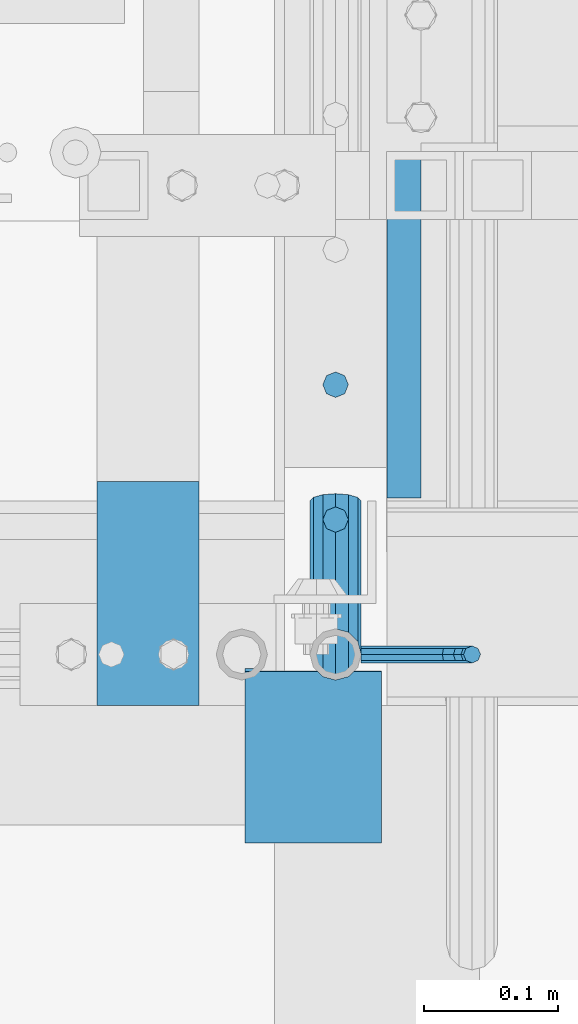
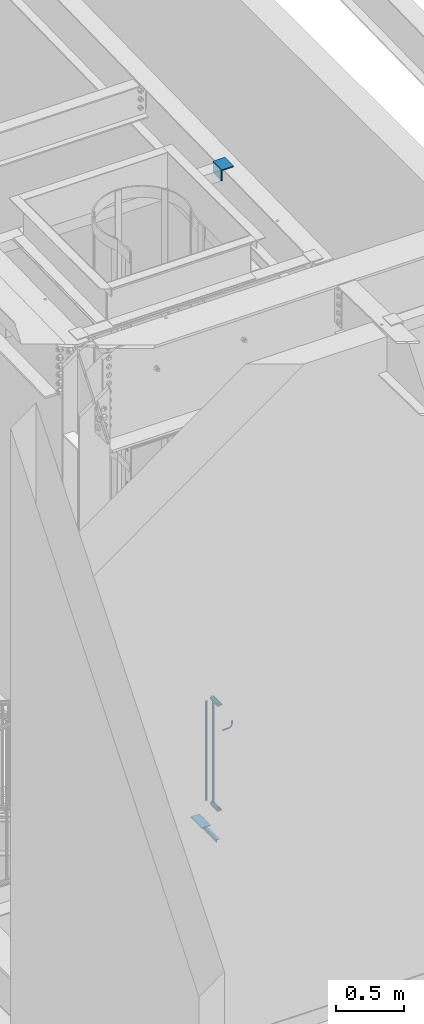
# One storey, part 1258 of 1763: 8 beams, 4 elements without a shape of their own.
"""IFC2X3 building model written with IfcOpenShell, lengths in millimetres."""

import ifcopenshell
import ifcopenshell.guid

model = None  # the IFC model being written
_history = None  # IfcOwnerHistory: only IFC2X3 demands one
_inside = {}  # id of a spatial element -> (the spatial element, [elements in it])
_under = {}  # id of a project, library or spatial element -> (it, [spatial elements below it])
_declared = {}  # id of a project -> (the project, [libraries it declares])
_typed = {}  # id of a type object -> (the type object, [elements of that type])
_made_of = {}  # id of a material, layer set ... -> (it, [elements and type objects made of it])


def new_model(schema):
    """Start an empty IFC model of exactly this schema.

    Asked for "IFC4X3", IfcOpenShell would pick the latest addendum, in which some entities
    have other attributes; the version numbers below select the first issue.
    IFC2X3 requires an IfcOwnerHistory on every rooted entity: one is made here for all.
    """
    global model, _history
    if schema == "IFC4X3":
        model = ifcopenshell.file(schema_version=(4, 3, 0, 0))
    else:
        model = ifcopenshell.file(schema=schema)
    _inside.clear()
    _under.clear()
    _declared.clear()
    _typed.clear()
    _made_of.clear()
    _history = None
    if model.schema == "IFC2X3":
        org = make("IfcOrganization", Name="unknown")
        user = make(
            "IfcPersonAndOrganization",
            ThePerson=make("IfcPerson", FamilyName="unknown"),
            TheOrganization=org,
        )
        app = make(
            "IfcApplication",
            ApplicationDeveloper=org,
            Version="unknown",
            ApplicationFullName="unknown",
            ApplicationIdentifier="unknown",
        )
        _history = make(
            "IfcOwnerHistory",
            OwningUser=user,
            OwningApplication=app,
            ChangeAction="ADDED",
            CreationDate=0,
        )
    return model


def make(cls, **values):
    """One entity of the class cls with the attributes given. An attribute that is None is left unset."""
    return model.create_entity(
        cls, **{name: value for name, value in values.items() if value is not None}
    )


def rooted(cls, **values):
    """An entity with a GlobalId (a new one), such as an element, a storey or a relation."""
    return make(cls, GlobalId=ifcopenshell.guid.new(), OwnerHistory=_history, **values)


def si_unit(unit_type, name, prefix=None):
    """IfcSIUnit, for example si_unit("LENGTHUNIT", "METRE", prefix="MILLI")."""
    return make("IfcSIUnit", UnitType=unit_type, Prefix=prefix, Name=name)


def assignment(units):
    """IfcUnitAssignment: the units of a project."""
    return None if units is None else make("IfcUnitAssignment", Units=units)


def point(xyz):
    """IfcCartesianPoint."""
    return None if xyz is None else make("IfcCartesianPoint", Coordinates=xyz)


def direction(xyz):
    """IfcDirection."""
    return None if xyz is None else make("IfcDirection", DirectionRatios=xyz)


def frame(location, z_axis=None, x_axis=None):
    """IfcAxis2Placement3D, a coordinate frame: its origin and axes. An axis left out is left unset."""
    return make(
        "IfcAxis2Placement3D",
        Location=point(location),
        Axis=direction(z_axis),
        RefDirection=direction(x_axis),
    )


def origin_with_axes():
    """The frame at (0, 0, 0) with the z axis (0, 0, 1) and the x axis (1, 0, 0) written out."""
    return frame((0.0, 0.0, 0.0), z_axis=(0.0, 0.0, 1.0), x_axis=(1.0, 0.0, 0.0))


def place(relative_to, where):
    """IfcLocalPlacement: puts the frame where relative to a parent placement (None: the world)."""
    return make(
        "IfcLocalPlacement", PlacementRelTo=relative_to, RelativePlacement=where
    )


def context(
    kind, dimensions, precision=None, world=None, true_north=None, identifier=None
):
    """IfcGeometricRepresentationContext, for example the 3D "Model" context."""
    return make(
        "IfcGeometricRepresentationContext",
        ContextIdentifier=identifier,
        ContextType=kind,
        CoordinateSpaceDimension=dimensions,
        Precision=precision,
        WorldCoordinateSystem=world,
        TrueNorth=true_north,
    )


def subcontext(parent, identifier, kind, view, scale=None):
    """IfcGeometricRepresentationSubContext, for example "Body" below "Model"."""
    return make(
        "IfcGeometricRepresentationSubContext",
        ContextIdentifier=identifier,
        ContextType=kind,
        ParentContext=parent,
        TargetScale=scale,
        TargetView=view,
    )


def project(units=None, contexts=None):
    """IfcProject with its units and contexts."""
    return rooted(
        "IfcProject",
        Name="project",
        RepresentationContexts=contexts,
        UnitsInContext=assignment(units),
    )


def spatial(cls, under=None, at=None, **own):
    """A site, building, storey or space (cls), placed at a placement, below another one or the project."""
    s = rooted(cls, ObjectPlacement=at, **own)
    if under is not None:
        _under.setdefault(under.id(), (under, []))[1].append(s)
    return s


def faces_of(points, faces, orient=None, outer=None):
    """IfcFace entities. A face is a list of loops; a loop is a list of indices into points, from 0.

    orient and outer hold one flag for each loop. By default every Orientation is true, the
    first loop of a face is its IfcFaceOuterBound and the others are IfcFaceBound.
    """
    made = []
    for i, loops in enumerate(faces):
        bounds = []
        for j, loop in enumerate(loops):
            is_outer = j == 0 if outer is None else outer[i][j]
            bounds.append(
                make(
                    "IfcFaceOuterBound" if is_outer else "IfcFaceBound",
                    Bound=make("IfcPolyLoop", Polygon=[points[k] for k in loop]),
                    Orientation=True if orient is None else orient[i][j],
                )
            )
        made.append(make("IfcFace", Bounds=bounds))
    return made


def faceted_brep(points, faces, orient=None, outer=None, voids=None):
    """IfcFacetedBrep: a solid bounded by flat faces; with voids (closed shells), ...WithVoids."""
    shared = [point(p) for p in points]
    hull = make("IfcClosedShell", CfsFaces=faces_of(shared, faces, orient, outer))
    if voids is None:
        return make("IfcFacetedBrep", Outer=hull)
    return make(
        "IfcFacetedBrepWithVoids",
        Outer=hull,
        Voids=[
            make(cls, CfsFaces=faces_of(shared, fs, o, b)) for cls, fs, o, b in voids
        ],
    )


def shape(context_of_items, identifier, shape_type, items):
    """IfcShapeRepresentation: the items that make up one representation, for example the "Body"."""
    return make(
        "IfcShapeRepresentation",
        ContextOfItems=context_of_items,
        RepresentationIdentifier=identifier,
        RepresentationType=shape_type,
        Items=items,
    )


def material(Name=None, Category=None):
    """IfcMaterial."""
    return make("IfcMaterial", Name=Name, Category=Category)


def made_of(thing, what):
    """Note that an element or type object is made of a material, layer set ...; save() writes the relation."""
    if what is not None:
        _made_of.setdefault(what.id(), (what, []))[1].append(thing)
    return thing


def type_object(cls, material=None, **own):
    """A type object (cls), such as IfcWallType, which elements share."""
    return made_of(rooted(cls, **own), material)


def element(
    cls,
    number,
    at=None,
    inside=None,
    cuts=None,
    type_object=None,
    material=None,
    context=None,
    identifier="Body",
    shape_type=None,
    held_by="IfcProductDefinitionShape",
    body=None,
    shapes=None,
    **own,
):
    """One element of the class cls, such as IfcWall. Its Tag is "e" and its number.

    at: its placement. inside: the storey or other place that contains it. cuts: it is an
    opening in that element (IfcRelVoidsElement). A single representation is given by context,
    identifier, shape_type and body (its items); several are given by shapes. held_by: the class
    of the entity that holds the representations. save() writes the other relations.
    """
    e = rooted(cls, Tag="e%d" % number, ObjectPlacement=at, **own)
    if body is not None:
        shapes = [shape(context, identifier, shape_type, body)]
    if shapes is not None:
        e.Representation = make(held_by, Representations=shapes)
    if inside is not None:
        _inside.setdefault(inside.id(), (inside, []))[1].append(e)
    if cuts is not None:
        rooted(
            "IfcRelVoidsElement", RelatingBuildingElement=cuts, RelatedOpeningElement=e
        )
    if type_object is not None:
        _typed.setdefault(type_object.id(), (type_object, []))[1].append(e)
    return made_of(e, material)


def aggregate(whole, parts):
    """IfcRelAggregates: a whole, such as a stair, and the parts it consists of."""
    return rooted("IfcRelAggregates", RelatingObject=whole, RelatedObjects=parts)


def save(model, path):
    """Write the relations noted so far, then the file.

    IfcRelAggregates (storeys below a building ...), IfcRelContainedInSpatialStructure (elements
    in a storey), IfcRelDefinesByType, IfcRelAssociatesMaterial and IfcRelDeclares: one each for
    every whole, place, type object, material and project.
    """
    for whole, parts in _under.values():
        aggregate(whole, parts)
    for where, things in _inside.values():
        rooted(
            "IfcRelContainedInSpatialStructure",
            RelatedElements=things,
            RelatingStructure=where,
        )
    for kind, things in _typed.values():
        rooted("IfcRelDefinesByType", RelatedObjects=things, RelatingType=kind)
    for what, things in _made_of.values():
        rooted("IfcRelAssociatesMaterial", RelatedObjects=things, RelatingMaterial=what)
    for by, libraries in _declared.values():
        rooted("IfcRelDeclares", RelatingContext=by, RelatedDefinitions=libraries)
    model.write(path)


model = new_model("IFC2X3")

# Units and contexts
model_context = context("Model", 3, precision=1e-05, world=origin_with_axes())
body_context = subcontext(model_context, "Body", "Model", "MODEL_VIEW")
ifc_project = project(units=[si_unit("LENGTHUNIT", "METRE", prefix="MILLI"), si_unit("AREAUNIT", "SQUARE_METRE"), si_unit("VOLUMEUNIT", "CUBIC_METRE"), si_unit("MASSUNIT", "GRAM", prefix="KILO"), si_unit("TIMEUNIT", "SECOND"), si_unit("PLANEANGLEUNIT", "RADIAN"), si_unit("SOLIDANGLEUNIT", "STERADIAN"), si_unit("THERMODYNAMICTEMPERATUREUNIT", "DEGREE_CELSIUS"), si_unit("LUMINOUSINTENSITYUNIT", "LUMEN")], contexts=[model_context])

# Site, building, storey
site_placement = place(None, origin_with_axes())
site = spatial("IfcSite", under=ifc_project, at=site_placement, CompositionType="ELEMENT")
building_placement = place(site_placement, origin_with_axes())
building = spatial("IfcBuilding", under=site, at=building_placement, Name="Undefined", CompositionType="ELEMENT")
storey_placement = place(building_placement, origin_with_axes())
storey = spatial("IfcBuildingStorey", under=building, at=storey_placement, Name="Undefined", CompositionType="ELEMENT", Elevation=0.0)

# Assembly, beams
assembly_1_placement = place(storey_placement, origin_with_axes())
assembly_1 = element("IfcElementAssembly", 1, at=assembly_1_placement, inside=storey, Name="RAIL", AssemblyPlace="NOTDEFINED", PredefinedType="RIGID_FRAME")
ifc_material_1 = material(Name="STEEL/A513")
beam_type_1 = type_object("IfcBeamType", PredefinedType="NOTDEFINED")
beam_1_placement = place(assembly_1_placement, frame((-85279.8721005486, 31673.7999996174, 6400.79999982416), z_axis=(0.0, 0.0, -1.0), x_axis=(0.0, 1.0, 0.0)))
beam_1 = element("IfcBeam", 2, at=beam_1_placement, type_object=beam_type_1, material=ifc_material_1, Name="RAIL", context=body_context, shape_type="Brep", body=[
    faceted_brep([(4.71409293822944e-08, -15.3669999999984, 0.0), (7.68350000096689, -13.3082123799541, 7.68350000000009), (112.108875269474, -13.3082123799541, 7.68350000000009), (114.299998441489, -15.3669999999984, 0.0), (13.3082123809218, -7.68349999999919, 13.3082123799554), (110.504861781919, -7.68349999999919, 13.3082123799559), (15.3670000009661, 0.0, 15.3670000000002), (109.917752097459, 0.0, 15.3670000000002), (13.3082123809218, 7.68349999999919, 13.3082123799554), (110.504861781919, 7.68349999999919, 13.3082123799559), (7.68350000096689, 13.3082123799541, 7.68350000000009), (112.108875269474, 13.3082123799541, 7.68350000000009), (4.71409293822944e-08, 15.3669999999984, 0.0), (114.299998441489, 15.3669999999984, 0.0), (-7.68349999903876, 13.3082123799541, -7.68350000000009), (116.491121613501, 13.3082123799541, -7.68350000000009), (-13.3082123789936, 7.68349999999919, -13.3082123799554), (118.095135101059, 7.68349999999919, -13.3082123799559), (-15.3669999990379, 0.0, -15.3670000000002), (118.682244785516, 0.0, -15.3670000000002), (-13.3082123789936, -7.68349999999919, -13.3082123799554), (118.095135101059, -7.68349999999919, -13.3082123799559), (-7.68349999903876, -13.3082123799541, -7.68350000000009), (116.491121613501, -13.3082123799541, -7.68350000000009), (0.0, -19.0500000000029, 0.0), (-9.52499999903375, -16.4977839420899, -9.52500000000009), (117.016266836548, -16.4977839420899, -9.52499999999964), (114.299998441489, -19.0500000000029, 0.0), (-16.4977839411295, -9.52499999999418, -16.4977839420935), (119.004713308725, -9.52499999999418, -16.4977839420935), (-19.0499999990352, 0.0, -19.0500000000002), (119.732535231604, 0.0, -19.0500000000002), (-16.4977839411295, 9.52499999999418, -16.4977839420935), (119.004713308725, 9.52499999999418, -16.4977839420935), (-9.52499999903375, 16.4977839420899, -9.52500000000009), (117.016266836548, 16.4977839420899, -9.52499999999964), (0.0, 19.0500000000029, 0.0), (114.299998441489, 19.0500000000029, 0.0), (9.52500000096188, 16.4977839420899, 9.52500000000009), (111.58373004643, 16.4977839420899, 9.52499999999964), (16.4977839430576, 9.52499999999418, 16.4977839420935), (109.595283574254, 9.52499999999418, 16.4977839420935), (19.0500000009633, 0.0, 19.0500000000002), (108.867461651371, 0.0, 19.0500000000002), (16.4977839430576, -9.52499999999418, 16.4977839420935), (109.595283574254, -9.52499999999418, 16.4977839420935), (9.52500000096188, -16.4977839420899, 9.52500000000009), (111.58373004643, -16.4977839420899, 9.52499999999964)], [[[0, 1, 2, 3]], [[1, 4, 5, 2]], [[4, 6, 7, 5]], [[6, 8, 9, 7]], [[8, 10, 11, 9]], [[10, 12, 13, 11]], [[12, 14, 15, 13]], [[14, 16, 17, 15]], [[16, 18, 19, 17]], [[18, 20, 21, 19]], [[20, 22, 23, 21]], [[22, 0, 3, 23]], [[24, 25, 26, 27]], [[25, 28, 29, 26]], [[28, 30, 31, 29]], [[30, 32, 33, 31]], [[32, 34, 35, 33]], [[34, 36, 37, 35]], [[36, 38, 39, 37]], [[38, 40, 41, 39]], [[40, 42, 43, 41]], [[42, 44, 45, 43]], [[44, 46, 47, 45]], [[46, 24, 27, 47]], [[29, 31, 33, 35, 37, 39, 41, 43, 45, 47, 27, 26], [5, 7, 9, 11, 13, 15, 17, 19, 21, 23, 3, 2]], [[46, 44, 42, 40, 38, 36, 34, 32, 30, 28, 25, 24], [22, 20, 18, 16, 14, 12, 10, 8, 6, 4, 1, 0]]]),
])
beam_2_placement = place(assembly_1_placement, frame((-85279.8721005486, 31788.0999981694, 5454.64999982416), z_axis=(0.0, 0.0, 1.0), x_axis=(0.0, -1.0, 0.0)))
beam_2 = element("IfcBeam", 3, at=beam_2_placement, type_object=beam_type_1, material=ifc_material_1, Name="RAIL", context=body_context, shape_type="Brep", body=[
    faceted_brep([(97.8022146099247, -9.52499999999418, 16.4977839420935), (97.8022146099247, -9.52500000000873, 11.4667123799409), (97.3087861720596, -7.68349999999919, 13.3082123799559), (95.249998552019, 0.0, 15.3670000000002), (95.249998552019, 0.0, 19.0500000000002), (97.3087861720669, 7.68349999999919, 13.3082123799559), (97.8022146099247, 9.52499999997963, 11.46671237997), (97.8022146099247, 9.52499999999418, 16.4977839420935), (114.299998441489, 19.0500000000029, 0.0), (104.774998552017, 16.4977839420899, 9.52499999999964), (104.774998552017, 16.4977839420899, -9.52499999999964), (101.585426989895, 13.3082123799541, 7.68350000000009), (103.64421460994, 15.3669999999984, 0.0), (101.585426989895, 13.3082123799541, -7.68350000000009), (97.8022146099247, 9.52499999997963, -11.46671237997), (97.8022146099247, 9.52499999999418, -16.4977839420935), (97.3087861720669, 7.68349999999919, -13.3082123799559), (95.249998552019, 0.0, -15.3670000000002), (95.249998552019, 0.0, -19.0500000000002), (97.8022146099247, -9.52500000000873, -11.4667123799409), (97.8022146099247, -9.52499999999418, -16.4977839420935), (97.3087861720596, -7.68349999999919, -13.3082123799559), (114.299998441489, -19.0500000000029, 0.0), (104.774998552017, -16.4977839420899, -9.52499999999964), (104.774998552017, -16.4977839420899, 9.52499999999964), (101.585426989866, -13.3082123799541, -7.68350000000009), (103.644214609911, -15.3669999999984, 0.0), (101.585426989866, -13.3082123799541, 7.68350000000009), (2.71626851754627, -16.4977839420899, -9.52499999999964), (4.70471498972256, -9.52499999999418, -16.4977839420935), (5.43253691260543, 0.0, -19.0500000000002), (4.70471498972256, 9.52499999999418, -16.4977839420935), (2.71626851754627, 16.4977839420899, -9.52499999999964), (0.0, 19.0500000000029, 0.0), (-2.71626827257205, 16.4977839420899, 9.52499999999964), (-4.70471474474834, 9.52499999999418, 16.4977839420935), (-5.43253666763121, 0.0, 19.0500000000002), (-4.70471474474834, -9.52499999999418, 16.4977839420935), (-2.71626827257205, -16.4977839420899, 9.52499999999964), (0.0, -19.0500000000029, 0.0), (2.19112329449854, -13.3082123799541, -7.68350000000009), (3.79513678205694, -7.68349999999919, -13.3082123799559), (4.38224646651361, 0.0, -15.3670000000002), (3.79513678205694, 7.68349999999919, -13.3082123799559), (2.19112329449854, 13.3082123799541, -7.68350000000009), (4.71409293822944e-08, 15.3669999999984, 0.0), (-2.19112304952796, 13.3082123799541, 7.68350000000009), (-3.79513653708273, 7.68349999999919, 13.3082123799559), (-4.38224622154303, 0.0, 15.3670000000002), (-3.79513653708273, -7.68349999999919, 13.3082123799559), (-2.19112304952796, -13.3082123799541, 7.68350000000009), (4.71409293822944e-08, -15.3669999999984, 0.0)], [[[0, 1, 2, 3, 4]], [[4, 3, 5, 6, 7]], [[8, 9, 10]], [[7, 6, 11, 12, 13, 14, 15, 10, 9]], [[16, 17, 18, 15, 14]], [[19, 20, 18, 17, 21]], [[22, 23, 24]], [[24, 23, 20, 19, 25, 26, 27, 1, 0]], [[28, 29, 20, 23]], [[29, 30, 18, 20]], [[30, 31, 15, 18]], [[31, 32, 10, 15]], [[32, 33, 8, 10]], [[33, 34, 9, 8]], [[34, 35, 7, 9]], [[35, 36, 4, 7]], [[36, 37, 0, 4]], [[37, 38, 24, 0]], [[38, 39, 22, 24]], [[39, 28, 23, 22]], [[38, 37, 36, 35, 34, 33, 32, 31, 30, 29, 28, 39], [40, 41, 42, 43, 44, 45, 46, 47, 48, 49, 50, 51]], [[40, 51, 26, 25]], [[21, 41, 40, 25, 19]], [[42, 41, 21, 17]], [[43, 42, 17, 16]], [[44, 43, 16, 14, 13]], [[45, 44, 13, 12]], [[46, 45, 12, 11]], [[5, 47, 46, 11, 6]], [[48, 47, 5, 3]], [[49, 48, 3, 2]], [[50, 49, 2, 1, 27]], [[51, 50, 27, 26]]]),
])

# Assembly, beam
assembly_2_placement = place(storey_placement, origin_with_axes())
assembly_2 = element("IfcElementAssembly", 4, at=assembly_2_placement, inside=storey, Name="ANGLE", AssemblyPlace="NOTDEFINED", PredefinedType="RIGID_FRAME")
ifc_material_2 = material(Name="STEEL/A36")
beam_type_2 = type_object("IfcBeamType", Name="L4X4X3/8", PredefinedType="NOTDEFINED")
beam_3_placement = place(assembly_2_placement, frame((-85296.5734375, 31662.2169564497, 11282.9677390736), z_axis=(0.0, 0.0209829029927459, -0.999779834654609), x_axis=(0.0, -0.999779834654609, -0.0209829029927513)))
beam_3 = element("IfcBeam", 5, at=beam_3_placement, type_object=beam_type_2, material=ifc_material_2, Name="ANGLE", ObjectType="L4X4X3/8", context=body_context, shape_type="Brep", body=[
    faceted_brep([(-3.63797880709171e-11, 50.8000000000011, -50.8000000000538), (-1.96450855582952e-10, 50.8000000000393, 50.7999999999374), (127.680357143057, 50.8000000000029, 50.8000000000775), (127.680357142966, 50.8000000000029, -50.7999999998556), (0.0, 41.2749999999996, 50.7999999999993), (127.680357143057, 41.2749999999942, 50.8000000000775), (0.0, 41.2749999999996, -41.2750000000015), (127.680357142981, 41.2749999999942, -41.2749999998596), (0.0, -50.7999999999993, -41.2750000000015), (127.680357142981, -50.8000000000029, -41.2749999998596), (2.11002770811319e-10, -50.8000000000357, -50.799999999952), (127.680357142966, -50.8000000000029, -50.7999999998556)], [[[0, 1, 2, 3]], [[1, 4, 5, 2]], [[4, 6, 7, 5]], [[6, 8, 9, 7]], [[8, 10, 11, 9]], [[10, 0, 3, 11]], [[5, 7, 9, 11, 3, 2]], [[10, 8, 6, 4, 1, 0]]]),
])
aggregate(assembly_2, [beam_3])

assembly_3_placement = place(storey_placement, origin_with_axes())
assembly_3 = element("IfcElementAssembly", 6, at=assembly_3_placement, inside=storey, Name="ref.", AssemblyPlace="NOTDEFINED", PredefinedType="NOTDEFINED")
ifc_material_3 = material()
beam_type_3 = type_object("IfcBeamType", PredefinedType="NOTDEFINED")
beam_4_placement = place(assembly_3_placement, frame((-85419.6372736932, 31802.5867641943, 5381.62499905101), z_axis=(1.0, 0.0, 0.0), x_axis=(0.0, -1.0, 0.0)))
beam_4 = element("IfcBeam", 7, at=beam_4_placement, type_object=beam_type_3, material=ifc_material_3, Name="ref.", context=body_context, shape_type="Brep", body=[
    faceted_brep([(0.0, 3.17500000000018, -38.0999999999985), (0.0, 3.17500000000018, 38.0999999999985), (166.886764211707, 3.1750000000111, 38.1000000000058), (166.886764211707, 3.1750000000111, -38.1000000000058), (0.0, -3.17500000000018, 38.0999999999985), (166.886764211711, -3.17499999998927, 38.1000000000058), (0.0, -3.17500000000018, -38.0999999999985), (166.886764211711, -3.17499999998927, -38.1000000000058)], [[[0, 1, 2, 3]], [[1, 4, 5, 2]], [[4, 6, 7, 5]], [[6, 0, 3, 7]], [[5, 7, 3, 2]], [[6, 4, 1, 0]]]),
])
aggregate(assembly_3, [beam_4])

# Beam
beam_type_4 = type_object("IfcBeamType", PredefinedType="NOTDEFINED")
beam_5_placement = place(assembly_1_placement, frame((-85260.8221005486, 31673.7999996173, 6172.20009613062), z_axis=(0.0, -1.0, 0.0), x_axis=(1.0, 0.0, 0.0)))
beam_5 = element("IfcBeam", 8, at=beam_5_placement, type_object=beam_type_4, material=ifc_material_2, Name="RAIL", context=body_context, shape_type="Brep", body=[
    faceted_brep([(0.0, -6.34999999999491, 1.45519152283669e-11), (-1.13686837721616e-13, -4.49012806053361, -4.49012806058454), (50.8000030517578, -4.49012806053452, -4.49012806053361), (50.8000030517578, -6.35000000000036, 0.0), (0.0, 0.0, -6.34999990463257), (50.8000030517578, 0.0, -6.34999999999854), (0.0, 4.49012806054088, -4.49012806053452), (50.8000030517578, 4.49012806053452, -4.49012806053361), (0.0, 6.34999999999491, -2.91038304567337e-11), (50.8000030517578, 6.35000000000036, 0.0), (0.0, 4.49012806054088, 4.49012806053452), (50.8000030517578, 4.49012806053452, 4.49012806053361), (0.0, 0.0, 6.34999990463257), (50.8000030517578, 0.0, 6.34999999999854), (0.0, -4.49012806053361, 4.49012806055543), (50.8000030517578, -4.49012806053452, 4.49012806053361), (65.380241824867, -3.44981018867929, 0.0), (64.6684996473195, -1.73151257071549, 4.49012806053361), (62.9502020293439, 2.4168248427668, 6.34999999999854), (61.2319044113829, 6.5651622562491, 4.49012806053361), (60.5201622338354, 8.2834598742138, 0.0), (61.2319044113829, 6.5651622562491, -4.49012806053361), (62.9502020293439, 2.4168248427668, -6.34999999999854), (64.6684996473195, -1.73151257071549, -4.49012806053361), (76.425643354436, 6.12435969732724, -4.49012806053361), (77.7407714149595, 4.8092316367929, 0.0), (73.2506433544331, 9.29935969732742, -6.34999999999854), (70.0756433544302, 12.4743596973276, -4.49012806053361), (68.7605152938922, 13.7894877578619, 0.0), (70.0756433544302, 12.4743596973276, 4.49012806053361), (73.2506433544331, 9.29935969732742, 6.34999999999854), (76.425643354436, 6.12435969732724, 4.49012806053361), (84.2815156224679, 17.8815034044446, -4.49012806053361), (85.9998132404435, 17.1697612268908, 0.0), (80.1331782089983, 19.5998010224093, -6.34999999999854), (75.9848407955142, 21.3180986403731, -4.49012806053361), (74.2665431775386, 22.0298408179269, 0.0), (75.9848407955142, 21.3180986403731, 4.49012806053361), (80.1331782089983, 19.5998010224093, 6.34999999999854), (84.2815156224679, 17.8815034044446, 4.49012806053361), (87.0401311122987, 31.75, -4.49012806053361), (88.9000030517636, 31.75, 0.0), (82.5500030517578, 31.75, -6.34999999999854), (78.0598749912169, 31.75, -4.49012806053361), (76.200003051752, 31.75, 0.0), (78.0598749912169, 31.75, 4.49012806053361), (82.5500030517578, 31.75, 6.34999999999854), (87.0401311122987, 31.75, 4.49012806053361), (87.0401311122987, 57.1500015258789, -4.49012806053361), (88.9000030517636, 57.1500015258789, 0.0), (82.5500030517578, 57.1500015258789, -6.34999999999854), (78.0598749912169, 57.1500015258789, -4.49012806053361), (76.200003051752, 57.1500015258789, 0.0), (78.0598749912169, 57.1500015258789, 4.49012806053361), (82.5500030517578, 57.1500015258789, 6.34999999999854), (87.0401311122987, 57.1500015258789, 4.49012806053361)], [[[0, 1, 2, 3]], [[1, 4, 5, 2]], [[4, 6, 7, 5]], [[6, 8, 9, 7]], [[8, 10, 11, 9]], [[10, 12, 13, 11]], [[12, 14, 15, 13]], [[14, 0, 3, 15]], [[14, 12, 10, 8, 6, 4, 1, 0]], [[15, 3, 16, 17]], [[13, 15, 17, 18]], [[11, 13, 18, 19]], [[9, 11, 19, 20]], [[7, 9, 20, 21]], [[5, 7, 21, 22]], [[2, 5, 22, 23]], [[3, 2, 23, 16]], [[23, 24, 25, 16]], [[22, 26, 24, 23]], [[21, 27, 26, 22]], [[20, 28, 27, 21]], [[19, 29, 28, 20]], [[18, 30, 29, 19]], [[17, 31, 30, 18]], [[16, 25, 31, 17]], [[24, 32, 33, 25]], [[26, 34, 32, 24]], [[27, 35, 34, 26]], [[28, 36, 35, 27]], [[29, 37, 36, 28]], [[30, 38, 37, 29]], [[31, 39, 38, 30]], [[25, 33, 39, 31]], [[32, 40, 41, 33]], [[34, 42, 40, 32]], [[35, 43, 42, 34]], [[36, 44, 43, 35]], [[37, 45, 44, 36]], [[38, 46, 45, 37]], [[39, 47, 46, 38]], [[33, 41, 47, 39]], [[41, 40, 48, 49]], [[40, 42, 50, 48]], [[42, 43, 51, 50]], [[43, 44, 52, 51]], [[44, 45, 53, 52]], [[45, 46, 54, 53]], [[46, 47, 55, 54]], [[47, 41, 49, 55]], [[50, 51, 52, 53, 54, 55, 49, 48]]]),
])

beam_type_5 = type_object("IfcBeamType", PredefinedType="NOTDEFINED")
beam_6_placement = place(assembly_1_placement, frame((-85279.8721005486, 31774.24545418, 6400.79999982416), z_axis=(1.0, 0.0, 0.0), x_axis=(0.0, 0.0, -1.0)))
beam_6 = element("IfcBeam", 9, at=beam_6_placement, type_object=beam_type_5, material=ifc_material_2, Name="PICKET", context=body_context, shape_type="Brep", body=[
    faceted_brep([(19.0499999999092, -9.52500000000146, 0.0), (19.0499999999092, -6.73519209080405, -6.73519209079677), (927.099999996084, -6.73519209080405, -6.73519209079677), (927.099999996084, -9.52500000000146, 0.0), (19.0499999999092, 0.0, -9.52499999999418), (927.099999996084, 0.0, -9.52499999999418), (19.0499999999092, 6.73519209080405, -6.73519209079677), (927.099999996084, 6.73519209080405, -6.73519209079677), (19.0499999999092, 9.52500000000146, 0.0), (927.099999996084, 9.52500000000146, 0.0), (19.0499999999092, 6.73519209080405, 6.73519209079677), (927.099999996084, 6.73519209080405, 6.73519209079677), (19.0499999999092, 0.0, 9.52499999999418), (927.099999996084, 0.0, 9.52499999999418), (19.0499999999092, -6.73519209080405, 6.73519209079677), (927.099999996084, -6.73519209080405, 6.73519209079677)], [[[0, 1, 2, 3]], [[1, 4, 5, 2]], [[4, 6, 7, 5]], [[6, 8, 9, 7]], [[8, 10, 11, 9]], [[10, 12, 13, 11]], [[12, 14, 15, 13]], [[14, 0, 3, 15]], [[5, 7, 9, 11, 13, 15, 3, 2]], [[14, 12, 10, 8, 6, 4, 1, 0]]]),
])

beam_7_placement = place(assembly_1_placement, frame((-85279.8721005486, 31874.6909087426, 6347.04147622038), z_axis=(1.0, 0.0, 0.0), x_axis=(0.0, 0.0, -1.0)))
beam_7 = element("IfcBeam", 10, at=beam_7_placement, type_object=beam_type_5, material=ifc_material_2, Name="PICKET", context=body_context, shape_type="Brep", body=[
    faceted_brep([(16.5092624764411, -9.52500000000146, 0.0), (18.2412682186596, -6.73519209080041, -6.73519209079677), (919.54586829654, -6.73519209080041, -6.73519209079677), (917.813862554322, -9.52500000000146, 0.0), (22.4226999716293, 0.0, -9.52499999999418), (923.727300049511, 0.0, -9.52499999999418), (26.6041317245999, 6.73519209080041, -6.73519209079677), (927.908731802481, 6.73519209080041, -6.73519209079677), (28.3361374668184, 9.52500000000146, 0.0), (929.6407375447, 9.52500000000146, 0.0), (26.6041317245999, 6.73519209080041, 6.73519209079677), (927.908731802481, 6.73519209080041, 6.73519209079677), (22.4226999716293, 0.0, 9.52499999999418), (923.727300049511, 0.0, 9.52499999999418), (18.2412682186596, -6.73519209080041, 6.73519209079677), (919.54586829654, -6.73519209080041, 6.73519209079677)], [[[0, 1, 2, 3]], [[1, 4, 5, 2]], [[4, 6, 7, 5]], [[6, 8, 9, 7]], [[8, 10, 11, 9]], [[10, 12, 13, 11]], [[12, 14, 15, 13]], [[14, 0, 3, 15]], [[5, 7, 9, 11, 13, 15, 3, 2]], [[14, 12, 10, 8, 6, 4, 1, 0]]]),
])

aggregate(assembly_1, [beam_5, beam_6, beam_7, beam_1, beam_2])

# Assembly, beam
assembly_4_placement = place(storey_placement, origin_with_axes())
assembly_4 = element("IfcElementAssembly", 11, at=assembly_4_placement, inside=storey, Name="STRINGER", AssemblyPlace="NOTDEFINED", PredefinedType="RIGID_FRAME")
beam_type_6 = type_object("IfcBeamType", Name="L1X1X1/8", PredefinedType="NOTDEFINED")
beam_8_placement = place(assembly_4_placement, frame((-85229.072101503, 31790.1524593326, 5093.86416686991), z_axis=(1.0, 0.0, 0.0), x_axis=(0.0, 1.0, 0.0)))
beam_8 = element("IfcBeam", 12, at=beam_8_placement, type_object=beam_type_6, material=ifc_material_2, Name="ANGLE", ObjectType="L1X1X1/8", context=body_context, shape_type="Brep", body=[
    faceted_brep([(3.93434019839663e-12, 12.6999999999978, -12.6999998092651), (-1.31614667686587e-12, 12.6999999999978, 12.6999998092651), (254.0, 12.69999981, 12.6999998099927), (254.0, 12.69999981, -12.6999998099927), (-1.06936913171421e-12, 9.52499999999854, 12.699999332428), (254.0, 9.52499985799977, 12.6999998099927), (0.0, 9.52499985799977, -9.52499985799659), (254.0, 9.52499985799977, -9.52499985799659), (0.0, -12.69999981, -9.52499985799659), (254.0, -12.69999981, -9.52499985799659), (0.0, -12.69999981, -12.6999998099927), (254.0, -12.69999981, -12.6999998099927)], [[[0, 1, 2, 3]], [[1, 4, 5, 2]], [[4, 6, 7, 5]], [[6, 8, 9, 7]], [[8, 10, 11, 9]], [[10, 0, 3, 11]], [[5, 7, 9, 11, 3, 2]], [[10, 8, 6, 4, 1, 0]]]),
])
aggregate(assembly_4, [beam_8])

save(model, "model.ifc")
